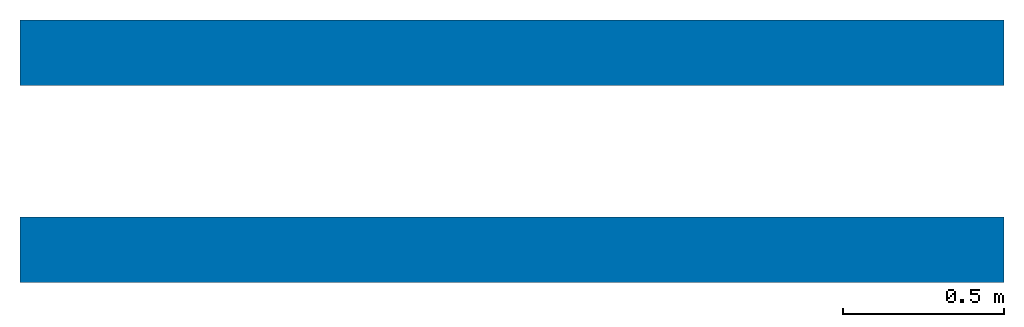
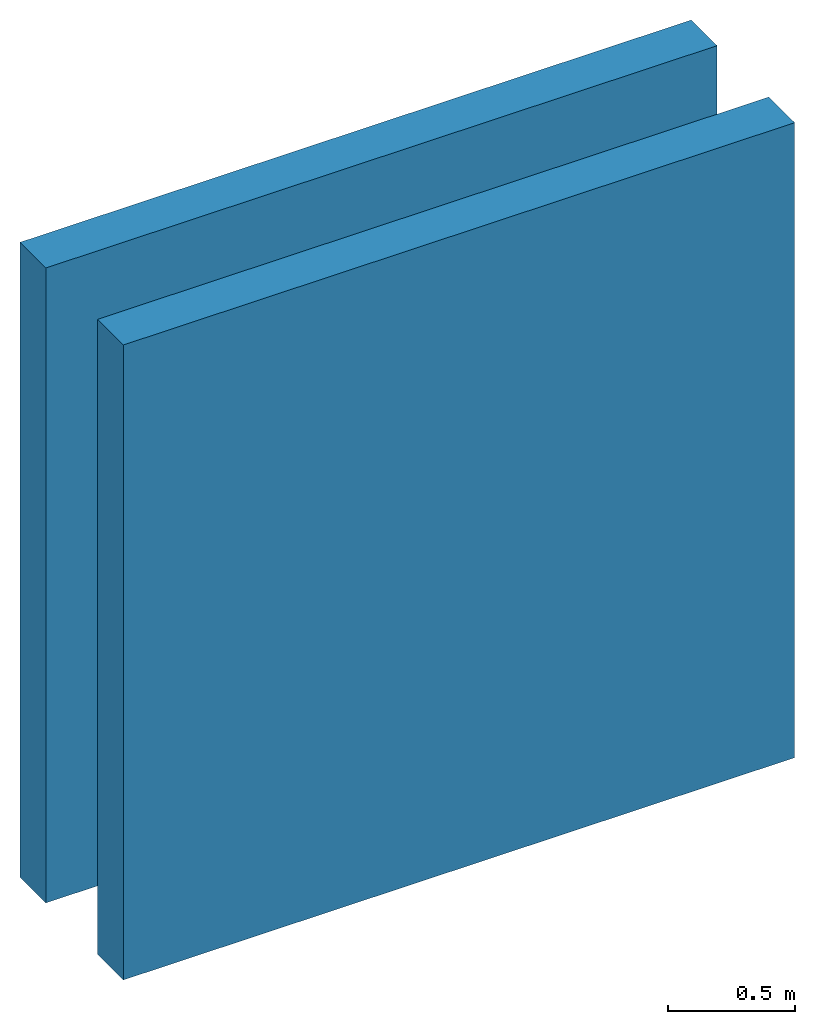
# One storey: 2 walls.
"""IFC2X3 building model written with IfcOpenShell, lengths in feet."""

from ifc_helpers import new_model, entity, si_unit, converted_unit, derived_unit, direction, frame, frame_2d, origin, place, context, subcontext, project, spatial, rectangle, extrude, material, layer, layer_set, layer_usage, type_object, element, save


model = new_model("IFC2X3")

# Units and contexts
model_context = context("Model", 3, precision=0.0001, world=origin(), true_north=direction((6.12303176911189e-17, 1.0)))
body_context = subcontext(model_context, "Body", "Model", "MODEL_VIEW")
ifc_project = project(units=[converted_unit("LENGTHUNIT", "FOOT", entity("IfcRatioMeasure", 0.3048), si_unit("LENGTHUNIT", "METRE"), dimensions=[1, 0, 0, 0, 0, 0, 0]), converted_unit("AREAUNIT", "SQUARE FOOT", entity("IfcRatioMeasure", 0.09290304), si_unit("AREAUNIT", "SQUARE_METRE"), dimensions=[2, 0, 0, 0, 0, 0, 0]), converted_unit("VOLUMEUNIT", "CUBIC FOOT", entity("IfcRatioMeasure", 0.028316846592), si_unit("VOLUMEUNIT", "CUBIC_METRE"), dimensions=[3, 0, 0, 0, 0, 0, 0]), converted_unit("PLANEANGLEUNIT", "DEGREE", entity("IfcRatioMeasure", 0.0174532925199433), si_unit("PLANEANGLEUNIT", "RADIAN"), dimensions=[0, 0, 0, 0, 0, 0, 0]), si_unit("MASSUNIT", "GRAM", prefix="KILO"), derived_unit("MASSDENSITYUNIT", [(si_unit("MASSUNIT", "GRAM", prefix="KILO"), 1), (si_unit("LENGTHUNIT", "METRE"), -3)]), si_unit("TIMEUNIT", "SECOND"), si_unit("FREQUENCYUNIT", "HERTZ"), si_unit("THERMODYNAMICTEMPERATUREUNIT", "DEGREE_CELSIUS"), derived_unit("THERMALTRANSMITTANCEUNIT", [(si_unit("MASSUNIT", "GRAM", prefix="KILO"), 1), (si_unit("THERMODYNAMICTEMPERATUREUNIT", "KELVIN"), -1), (si_unit("TIMEUNIT", "SECOND"), -3)]), derived_unit("VOLUMETRICFLOWRATEUNIT", [(si_unit("LENGTHUNIT", "METRE"), 3), (si_unit("TIMEUNIT", "SECOND"), -1)]), si_unit("ELECTRICCURRENTUNIT", "AMPERE"), si_unit("ELECTRICVOLTAGEUNIT", "VOLT"), si_unit("POWERUNIT", "WATT"), si_unit("FORCEUNIT", "NEWTON"), si_unit("ILLUMINANCEUNIT", "LUX"), si_unit("LUMINOUSFLUXUNIT", "LUMEN"), si_unit("LUMINOUSINTENSITYUNIT", "CANDELA"), derived_unit("USERDEFINED", [(si_unit("MASSUNIT", "GRAM", prefix="KILO"), -1), (si_unit("LENGTHUNIT", "METRE"), -2), (si_unit("TIMEUNIT", "SECOND"), 3), (si_unit("LUMINOUSFLUXUNIT", "LUMEN"), 1)]), derived_unit("LINEARVELOCITYUNIT", [(si_unit("LENGTHUNIT", "METRE"), 1), (si_unit("TIMEUNIT", "SECOND"), -1)]), si_unit("PRESSUREUNIT", "PASCAL"), derived_unit("USERDEFINED", [(si_unit("LENGTHUNIT", "METRE"), -2), (si_unit("MASSUNIT", "GRAM", prefix="KILO"), 1), (si_unit("TIMEUNIT", "SECOND"), -2)]), derived_unit("LINEARFORCEUNIT", [(si_unit("MASSUNIT", "GRAM", prefix="KILO"), 1), (si_unit("LENGTHUNIT", "METRE"), 1), (si_unit("TIMEUNIT", "SECOND"), -2), (si_unit("LENGTHUNIT", "METRE"), -1)]), derived_unit("PLANARFORCEUNIT", [(si_unit("MASSUNIT", "GRAM", prefix="KILO"), 1), (si_unit("LENGTHUNIT", "METRE"), 1), (si_unit("TIMEUNIT", "SECOND"), -2), (si_unit("LENGTHUNIT", "METRE"), -2)])], contexts=[model_context])

# Site, building, storey
site_placement = place(None, origin())
site = spatial("IfcSite", under=ifc_project, at=site_placement, CompositionType="ELEMENT")
building_placement = place(site_placement, origin())
building = spatial("IfcBuilding", under=site, at=building_placement, CompositionType="ELEMENT")
storey_placement = place(building_placement, origin())
storey = spatial("IfcBuildingStorey", under=building, at=storey_placement, Name="Level 1", CompositionType="ELEMENT", Elevation=0.0)

# Walls
ifc_material_1 = material(Name="1")
ifc_layer_1 = layer(ifc_material_1, 0.333333333333333)
ifc_material_2 = material(Name="2")
ifc_layer_2 = layer(ifc_material_2, 0.333333333333333)
ifc_layer_set = layer_set([ifc_layer_1, ifc_layer_2])
ifc_layer_usage_1 = layer_usage(ifc_layer_set, "AXIS2", "NEGATIVE", 0.333333333333333)
wall_type = type_object("IfcWallType", PredefinedType="STANDARD", material=ifc_layer_set)
wall_1_placement = place(storey_placement, origin())
element("IfcWallStandardCase", 1, at=wall_1_placement, inside=storey, type_object=wall_type, material=ifc_layer_usage_1, context=body_context, shape_type="SweptSolid", body=[
    extrude(rectangle(XDim=10.0, YDim=0.666666666666667, at=frame_2d((5.0, 0.0), x_axis=(-1.0, 0.0))), origin(), (0.0, 0.0, 1.0), 10.0),
])
ifc_layer_usage_2 = layer_usage(ifc_layer_set, "AXIS2", "NEGATIVE", 0.333333333333333)
wall_2_placement = place(storey_placement, frame((0.0, 2.0, 0.0)))
element("IfcWallStandardCase", 2, at=wall_2_placement, inside=storey, type_object=wall_type, material=ifc_layer_usage_2, context=body_context, shape_type="SweptSolid", body=[
    extrude(rectangle(XDim=10.0, YDim=0.666666666666666, at=frame_2d((5.0, -8.32667268468867e-17), x_axis=(-1.0, 0.0))), origin(), (0.0, 0.0, 1.0), 10.0),
])

save(model, "model.ifc")
